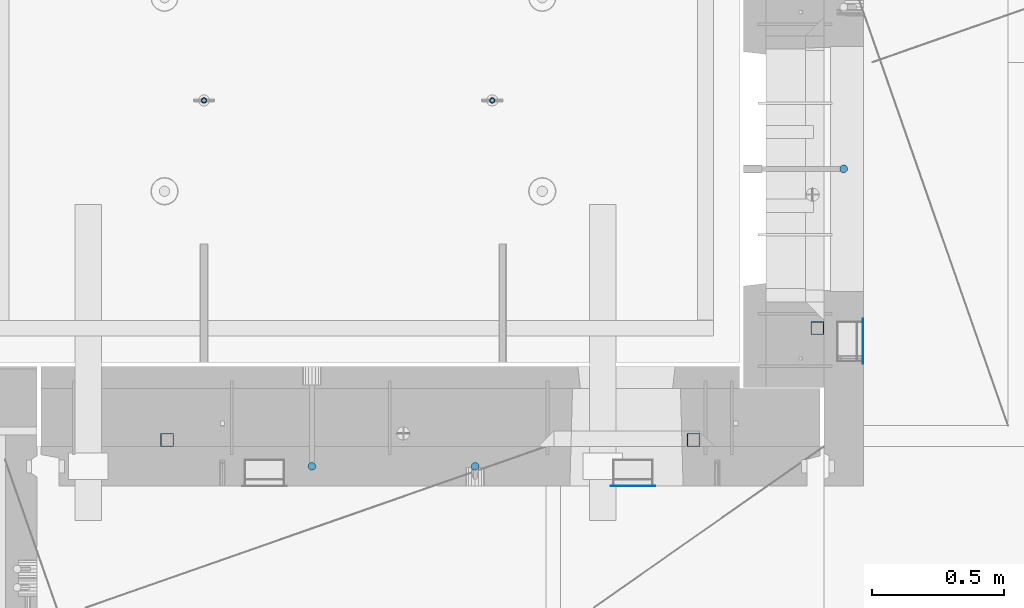
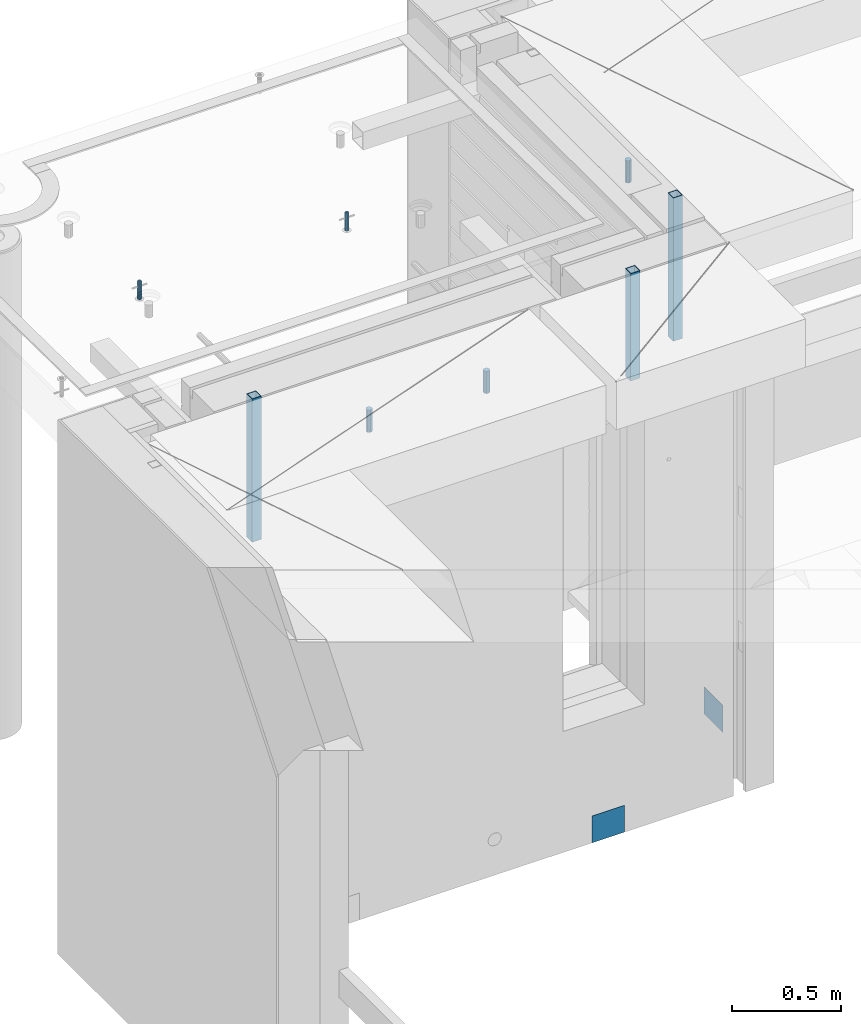
# One storey, part 27 of 349: 10 columns, 10 elements without a shape of their own.
"""IFC2X3 building model written with IfcOpenShell, lengths in millimetres."""

from ifc_helpers import new_model, si_unit, frame, origin_with_axes, place, context, subcontext, project, spatial, faceted_brep, material, type_object, element, aggregate, save


model = new_model("IFC2X3")

# Units and contexts
model_context = context("Model", 3, precision=1e-05, world=origin_with_axes())
body_context = subcontext(model_context, "Body", "Model", "MODEL_VIEW")
ifc_project = project(units=[si_unit("LENGTHUNIT", "METRE", prefix="MILLI"), si_unit("AREAUNIT", "SQUARE_METRE"), si_unit("VOLUMEUNIT", "CUBIC_METRE"), si_unit("MASSUNIT", "GRAM", prefix="KILO"), si_unit("TIMEUNIT", "SECOND"), si_unit("PLANEANGLEUNIT", "RADIAN"), si_unit("SOLIDANGLEUNIT", "STERADIAN"), si_unit("THERMODYNAMICTEMPERATUREUNIT", "DEGREE_CELSIUS"), si_unit("LUMINOUSINTENSITYUNIT", "LUMEN")], contexts=[model_context])

# Site, building, storey
site_placement = place(None, origin_with_axes())
site = spatial("IfcSite", under=ifc_project, at=site_placement, CompositionType="ELEMENT")
building_placement = place(site_placement, origin_with_axes())
building = spatial("IfcBuilding", under=site, at=building_placement, CompositionType="ELEMENT")
storey_placement = place(building_placement, origin_with_axes())
storey = spatial("IfcBuildingStorey", under=building, at=storey_placement, Name="4", CompositionType="ELEMENT", Elevation=0.0)

# Assembly, column
assembly_1_placement = place(storey_placement, origin_with_axes())
assembly_1 = element("IfcElementAssembly", 1, at=assembly_1_placement, inside=storey, AssemblyPlace="NOTDEFINED", PredefinedType="REINFORCEMENT_UNIT")
ifc_material_1 = material()
column_type_1 = type_object("IfcColumnType", Name="D30", PredefinedType="NOTDEFINED")
column_1_placement = place(assembly_1_placement, frame((11064.9999999907, 21634.9982799657, 93407.5), z_axis=(1.0, 0.0, 0.0), x_axis=(0.0, 0.0, 1.0)))
column_1 = element("IfcColumn", 2, at=column_1_placement, type_object=column_type_1, material=ifc_material_1, ObjectType="D30", context=body_context, shape_type="Brep", body=[
    faceted_brep([(0.0, -15.0, 0.0), (0.0, -12.9903810567666, -7.5), (125.0, -12.9903810567666, -7.5), (125.0, -15.0, 0.0), (0.0, -7.5, -12.9903810567666), (125.0, -7.5, -12.9903810567666), (0.0, 0.0, -15.0), (125.0, 0.0, -15.0), (0.0, 7.5, -12.9903810567666), (125.0, 7.5, -12.9903810567666), (0.0, 12.9903810567666, -7.5), (125.0, 12.9903810567666, -7.5), (0.0, 15.0, 0.0), (125.0, 15.0, 0.0), (0.0, 12.9903810567666, 7.5), (125.0, 12.9903810567666, 7.5), (0.0, 7.5, 12.9903810567666), (125.0, 7.5, 12.9903810567666), (0.0, 0.0, 15.0), (125.0, 0.0, 15.0), (0.0, -7.5, 12.9903810567666), (125.0, -7.5, 12.9903810567666), (0.0, -12.9903810567666, 7.5), (125.0, -12.9903810567666, 7.5)], [[[0, 1, 2, 3]], [[1, 4, 5, 2]], [[4, 6, 7, 5]], [[6, 8, 9, 7]], [[8, 10, 11, 9]], [[10, 12, 13, 11]], [[12, 14, 15, 13]], [[14, 16, 17, 15]], [[16, 18, 19, 17]], [[18, 20, 21, 19]], [[20, 22, 23, 21]], [[22, 0, 3, 23]], [[5, 7, 9, 11, 13, 15, 17, 19, 21, 23, 3, 2]], [[22, 20, 18, 16, 14, 12, 10, 8, 6, 4, 1, 0]]]),
])

# Assembly, columns
assembly_2_placement = place(storey_placement, origin_with_axes())
assembly_2 = element("IfcElementAssembly", 3, at=assembly_2_placement, inside=storey, AssemblyPlace="NOTDEFINED", PredefinedType="REINFORCEMENT_UNIT")
column_2_placement = place(assembly_2_placement, frame((9665.00172003435, 20504.9951872276, 93407.5), z_axis=(0.0, 1.0, 0.0), x_axis=(0.0, 0.0, 1.0)))
column_2 = element("IfcColumn", 4, at=column_2_placement, type_object=column_type_1, material=ifc_material_1, ObjectType="D30", context=body_context, shape_type="Brep", body=[
    faceted_brep([(0.0, -15.0, 0.0), (0.0, -12.9903810567666, -7.5), (125.0, -12.9903810567666, -7.5), (125.0, -15.0, 0.0), (0.0, -7.5, -12.9903810567666), (125.0, -7.5, -12.9903810567666), (0.0, 0.0, -15.0), (125.0, 0.0, -15.0), (0.0, 7.5, -12.9903810567666), (125.0, 7.5, -12.9903810567666), (0.0, 12.9903810567666, -7.5), (125.0, 12.9903810567666, -7.5), (0.0, 15.0, 0.0), (125.0, 15.0, 0.0), (0.0, 12.9903810567666, 7.5), (125.0, 12.9903810567666, 7.5), (0.0, 7.5, 12.9903810567666), (125.0, 7.5, 12.9903810567666), (0.0, 0.0, 15.0), (125.0, 0.0, 15.0), (0.0, -7.5, 12.9903810567666), (125.0, -7.5, 12.9903810567666), (0.0, -12.9903810567666, 7.5), (125.0, -12.9903810567666, 7.5)], [[[0, 1, 2, 3]], [[1, 4, 5, 2]], [[4, 6, 7, 5]], [[6, 8, 9, 7]], [[8, 10, 11, 9]], [[10, 12, 13, 11]], [[12, 14, 15, 13]], [[14, 16, 17, 15]], [[16, 18, 19, 17]], [[18, 20, 21, 19]], [[20, 22, 23, 21]], [[22, 0, 3, 23]], [[5, 7, 9, 11, 13, 15, 17, 19, 21, 23, 3, 2]], [[22, 20, 18, 16, 14, 12, 10, 8, 6, 4, 1, 0]]]),
])
column_3_placement = place(assembly_2_placement, frame((9045.00366673532, 20504.9951872205, 93407.5), z_axis=(0.0, -1.0, 0.0), x_axis=(0.0, 0.0, 1.0)))
column_3 = element("IfcColumn", 5, at=column_3_placement, type_object=column_type_1, material=ifc_material_1, ObjectType="D30", context=body_context, shape_type="Brep", body=[
    faceted_brep([(0.0, -15.0, 0.0), (0.0, -12.9903810567666, -7.5), (125.0, -12.9903810567666, -7.5), (125.0, -15.0, 0.0), (0.0, -7.5, -12.9903810567666), (125.0, -7.5, -12.9903810567666), (0.0, 0.0, -15.0), (125.0, 0.0, -15.0), (0.0, 7.5, -12.9903810567666), (125.0, 7.5, -12.9903810567666), (0.0, 12.9903810567666, -7.5), (125.0, 12.9903810567666, -7.5), (0.0, 15.0, 0.0), (125.0, 15.0, 0.0), (0.0, 12.9903810567666, 7.5), (125.0, 12.9903810567666, 7.5), (0.0, 7.5, 12.9903810567666), (125.0, 7.5, 12.9903810567666), (0.0, 0.0, 15.0), (125.0, 0.0, 15.0), (0.0, -7.5, 12.9903810567666), (125.0, -7.5, 12.9903810567666), (0.0, -12.9903810567666, 7.5), (125.0, -12.9903810567666, 7.5)], [[[0, 1, 2, 3]], [[1, 4, 5, 2]], [[4, 6, 7, 5]], [[6, 8, 9, 7]], [[8, 10, 11, 9]], [[10, 12, 13, 11]], [[12, 14, 15, 13]], [[14, 16, 17, 15]], [[16, 18, 19, 17]], [[18, 20, 21, 19]], [[20, 22, 23, 21]], [[22, 0, 3, 23]], [[5, 7, 9, 11, 13, 15, 17, 19, 21, 23, 3, 2]], [[22, 20, 18, 16, 14, 12, 10, 8, 6, 4, 1, 0]]]),
])

# Assembly, column
assembly_3_placement = place(assembly_1_placement, origin_with_axes())
assembly_3 = element("IfcElementAssembly", 6, at=assembly_3_placement, Name="Steel Assembly", AssemblyPlace="NOTDEFINED", PredefinedType="NOTDEFINED")
ifc_material_2 = material(Name="Undefined")
column_type_2 = type_object("IfcColumnType", PredefinedType="NOTDEFINED")
column_4_placement = place(assembly_3_placement, frame((11139.0000000031, 20979.9951872276, 90754.9999999969), z_axis=(1.0, 0.0, 0.0), x_axis=(0.0, 0.0, 1.0)))
column_4 = element("IfcColumn", 7, at=column_4_placement, type_object=column_type_2, material=ifc_material_2, Name="SPK2", context=body_context, shape_type="Brep", body=[
    faceted_brep([(0.0, 85.0, -1.0), (0.0, 85.0, 1.0), (150.0, 85.0, 1.0), (150.0, 85.0, -1.0), (0.0, -85.0, 1.0), (150.0, -85.0, 1.0), (0.0, -85.0, -1.0), (150.0, -85.0, -1.0)], [[[0, 1, 2, 3]], [[1, 4, 5, 2]], [[4, 6, 7, 5]], [[6, 0, 3, 7]], [[5, 7, 3, 2]], [[6, 4, 1, 0]]]),
])
aggregate(assembly_3, [column_4])

assembly_4_placement = place(assembly_2_placement, origin_with_axes())
assembly_4 = element("IfcElementAssembly", 8, at=assembly_4_placement, Name="Steel Assembly", AssemblyPlace="NOTDEFINED", PredefinedType="NOTDEFINED")
column_5_placement = place(assembly_4_placement, frame((10265.0, 20430.9951872214, 90755.0), z_axis=(0.0, -1.0, 0.0), x_axis=(0.0, 0.0, 1.0)))
column_5 = element("IfcColumn", 9, at=column_5_placement, type_object=column_type_2, material=ifc_material_2, Name="SPK2", context=body_context, shape_type="Brep", body=[
    faceted_brep([(0.0, 85.0, -1.0), (0.0, 85.0, 1.0), (150.0, 85.0, 1.0), (150.0, 85.0, -1.0), (0.0, -85.0, 1.0), (150.0, -85.0, 1.0), (0.0, -85.0, -1.0), (150.0, -85.0, -1.0)], [[[0, 1, 2, 3]], [[1, 4, 5, 2]], [[4, 6, 7, 5]], [[6, 0, 3, 7]], [[5, 7, 3, 2]], [[6, 4, 1, 0]]]),
])
aggregate(assembly_4, [column_5])

# Assembly
assembly_5_placement = place(assembly_1_placement, origin_with_axes())
assembly_5 = element("IfcElementAssembly", 10, at=assembly_5_placement, Name="Steel Assembly", AssemblyPlace="NOTDEFINED", PredefinedType="RIGID_FRAME")

aggregate(assembly_1, [column_1, assembly_3, assembly_5])

# Column
ifc_material_3 = material(Name="STEEL/S355J2")
column_type_3 = type_object("IfcColumnType", Name="50X50X3", PredefinedType="NOTDEFINED")
column_6_placement = place(assembly_5_placement, frame((10965.0, 21030.0, 92940.0), z_axis=(1.0, 0.0, 0.0), x_axis=(0.0, 0.0, 1.0)))
column_6 = element("IfcColumn", 11, at=column_6_placement, type_object=column_type_3, material=ifc_material_3, ObjectType="50X50X3", context=body_context, shape_type="Brep", body=[
    faceted_brep([(0.0, 22.0, -22.0), (0.0, -22.0, -22.0), (800.0, -22.0, -22.0), (800.0, 22.0, -22.0), (0.0, -22.0, 22.0), (800.0, -22.0, 22.0), (0.0, 22.0, 22.0), (800.0, 22.0, 22.0), (0.0, 25.0, -25.0), (0.0, 25.0, 25.0), (800.0, 25.0, 25.0), (800.0, 25.0, -25.0), (0.0, -25.0, 25.0), (800.0, -25.0, 25.0), (0.0, -25.0, -25.0), (800.0, -25.0, -25.0)], [[[0, 1, 2, 3]], [[1, 4, 5, 2]], [[4, 6, 7, 5]], [[6, 0, 3, 7]], [[8, 9, 10, 11]], [[9, 12, 13, 10]], [[12, 14, 15, 13]], [[14, 8, 11, 15]], [[13, 15, 11, 10], [5, 7, 3, 2]], [[14, 12, 9, 8], [6, 4, 1, 0]]]),
])

aggregate(assembly_5, [column_6])

# Assembly, column
assembly_6_placement = place(assembly_2_placement, origin_with_axes())
assembly_6 = element("IfcElementAssembly", 12, at=assembly_6_placement, Name="Steel Assembly", AssemblyPlace="NOTDEFINED", PredefinedType="RIGID_FRAME")
column_7_placement = place(assembly_6_placement, frame((8495.0, 20605.0, 92940.0), z_axis=(1.0, 0.0, 0.0), x_axis=(0.0, 0.0, 1.0)))
column_7 = element("IfcColumn", 13, at=column_7_placement, type_object=column_type_3, material=ifc_material_3, ObjectType="50X50X3", context=body_context, shape_type="Brep", body=[
    faceted_brep([(0.0, 22.0, -22.0), (0.0, -22.0, -22.0), (800.0, -22.0, -22.0), (800.0, 22.0, -22.0), (0.0, -22.0, 22.0), (800.0, -22.0, 22.0), (0.0, 22.0, 22.0), (800.0, 22.0, 22.0), (0.0, 25.0, -25.0), (0.0, 25.0, 25.0), (800.0, 25.0, 25.0), (800.0, 25.0, -25.0), (0.0, -25.0, 25.0), (800.0, -25.0, 25.0), (0.0, -25.0, -25.0), (800.0, -25.0, -25.0)], [[[0, 1, 2, 3]], [[1, 4, 5, 2]], [[4, 6, 7, 5]], [[6, 0, 3, 7]], [[8, 9, 10, 11]], [[9, 12, 13, 10]], [[12, 14, 15, 13]], [[14, 8, 11, 15]], [[13, 15, 11, 10], [5, 7, 3, 2]], [[14, 12, 9, 8], [6, 4, 1, 0]]]),
])
aggregate(assembly_6, [column_7])

# Assembly
assembly_7_placement = place(assembly_2_placement, origin_with_axes())
assembly_7 = element("IfcElementAssembly", 14, at=assembly_7_placement, Name="Steel Assembly", AssemblyPlace="NOTDEFINED", PredefinedType="RIGID_FRAME")

aggregate(assembly_2, [column_2, column_3, assembly_4, assembly_6, assembly_7])

# Column
column_8_placement = place(assembly_7_placement, frame((10495.0, 20605.0, 93140.0), z_axis=(1.0, 0.0, 0.0), x_axis=(0.0, 0.0, 1.0)))
column_8 = element("IfcColumn", 15, at=column_8_placement, type_object=column_type_3, material=ifc_material_3, ObjectType="50X50X3", context=body_context, shape_type="Brep", body=[
    faceted_brep([(0.0, 22.0, -22.0), (0.0, -22.0, -22.0), (600.0, -22.0, -22.0), (600.0, 22.0, -22.0), (0.0, -22.0, 22.0), (600.0, -22.0, 22.0), (0.0, 22.0, 22.0), (600.0, 22.0, 22.0), (0.0, 25.0, -25.0), (0.0, 25.0, 25.0), (600.0, 25.0, 25.0), (600.0, 25.0, -25.0), (0.0, -25.0, 25.0), (600.0, -25.0, 25.0), (0.0, -25.0, -25.0), (600.0, -25.0, -25.0)], [[[0, 1, 2, 3]], [[1, 4, 5, 2]], [[4, 6, 7, 5]], [[6, 0, 3, 7]], [[8, 9, 10, 11]], [[9, 12, 13, 10]], [[12, 14, 15, 13]], [[14, 8, 11, 15]], [[13, 15, 11, 10], [5, 7, 3, 2]], [[14, 12, 9, 8], [6, 4, 1, 0]]]),
])

aggregate(assembly_7, [column_8])

# Assemblies, columns
assembly_8_placement = place(storey_placement, origin_with_axes())
assembly_8 = element("IfcElementAssembly", 16, at=assembly_8_placement, inside=storey, AssemblyPlace="NOTDEFINED", PredefinedType="REINFORCEMENT_UNIT")
assembly_9_placement = place(assembly_8_placement, origin_with_axes())
assembly_9 = element("IfcElementAssembly", 17, at=assembly_9_placement, Name="Steel Assembly", AssemblyPlace="NOTDEFINED", PredefinedType="RIGID_FRAME")
ifc_material_4 = material(Name="STEEL/1.4301")
column_type_4 = type_object("IfcColumnType", PredefinedType="NOTDEFINED")
column_9_placement = place(assembly_9_placement, frame((8634.9865866494, 21895.0212615308, 93444.9999983246), z_axis=(-1.60829999983552e-05, -0.999999999870669, 0.0), x_axis=(0.0, 0.0, 1.0)))
column_9 = element("IfcColumn", 18, at=column_9_placement, type_object=column_type_4, material=ifc_material_4, context=body_context, shape_type="Brep", body=[
    faceted_brep([(0.0, -8.0, 0.0), (0.0, -6.92820323027263, 4.0), (100.000000000029, -6.92820323027263, 4.0), (100.000000000029, -7.99999999999636, 0.0), (0.0, -4.0, 6.92820323027627), (100.000000000029, -4.0, 6.92820323027536), (0.0, 0.0, 8.0), (100.000000000029, 3.63797880709171e-12, 8.0), (0.0, 4.0, 6.92820323027627), (100.000000000029, 4.0, 6.92820323027536), (0.0, 6.92820323027263, 4.0), (100.000000000029, 6.92820323027627, 3.99999999999909), (0.0, 8.0, 0.0), (100.000000000029, 8.0, 0.0), (0.0, 6.92820323027263, -4.0), (100.000000000029, 6.92820323027627, -4.00000000000091), (0.0, 4.0, -6.92820323027627), (100.000000000029, 4.00000000000364, -6.92820323027536), (0.0, 0.0, -8.0), (100.000000000029, 3.63797880709171e-12, -8.00000000000091), (0.0, -4.0, -6.92820323027627), (100.000000000029, -3.99999999999636, -6.92820323027627), (0.0, -6.92820323027263, -4.0), (100.000000000029, -6.92820323027263, -4.0), (0.0, -10.4999999999927, -1.45519152283669e-11), (0.0, -9.09326673972828, -5.25000000001455), (100.000000000262, -9.09326673972828, -5.25000000001455), (100.000000000262, -10.4999999999927, -1.45519152283669e-11), (0.0, -5.24999999998545, -9.09326673974283), (100.000000000262, -5.24999999998545, -9.09326673974283), (0.0, 7.27595761418343e-12, -10.5), (100.000000000262, 7.27595761418343e-12, -10.5), (0.0, 5.25000000001455, -9.09326673975738), (100.000000000262, 5.25000000001455, -9.09326673975738), (0.0, 9.09326673975011, -5.25000000001455), (100.000000000262, 9.09326673975011, -5.25000000001455), (0.0, 10.5000000000073, -1.45519152283669e-11), (100.000000000262, 10.5000000000073, -1.45519152283669e-11), (0.0, 9.09326673975011, 5.25), (100.000000000262, 9.09326673975011, 5.25), (0.0, 5.25000000000728, 9.09326673972828), (100.000000000262, 5.25000000000728, 9.09326673972828), (0.0, 1.45519152283669e-11, 10.4999999999854), (100.000000000262, 1.45519152283669e-11, 10.4999999999854), (0.0, -5.24999999999272, 9.09326673972828), (100.000000000262, -5.24999999999272, 9.09326673972828), (0.0, -9.09326673972828, 5.24999999998545), (100.000000000262, -9.09326673972828, 5.24999999998545)], [[[0, 1, 2, 3]], [[1, 4, 5, 2]], [[4, 6, 7, 5]], [[6, 8, 9, 7]], [[8, 10, 11, 9]], [[10, 12, 13, 11]], [[12, 14, 15, 13]], [[14, 16, 17, 15]], [[16, 18, 19, 17]], [[18, 20, 21, 19]], [[20, 22, 23, 21]], [[22, 0, 3, 23]], [[24, 25, 26, 27]], [[25, 28, 29, 26]], [[28, 30, 31, 29]], [[30, 32, 33, 31]], [[32, 34, 35, 33]], [[34, 36, 37, 35]], [[36, 38, 39, 37]], [[38, 40, 41, 39]], [[40, 42, 43, 41]], [[42, 44, 45, 43]], [[44, 46, 47, 45]], [[46, 24, 27, 47]], [[29, 31, 33, 35, 37, 39, 41, 43, 45, 47, 27, 26], [5, 7, 9, 11, 13, 15, 17, 19, 21, 23, 3, 2]], [[46, 44, 42, 40, 38, 36, 34, 32, 30, 28, 25, 24], [22, 20, 18, 16, 14, 12, 10, 8, 6, 4, 1, 0]]]),
])
aggregate(assembly_9, [column_9])
assembly_10_placement = place(assembly_8_placement, origin_with_axes())
assembly_10 = element("IfcElementAssembly", 19, at=assembly_10_placement, Name="Steel Assembly", AssemblyPlace="NOTDEFINED", PredefinedType="RIGID_FRAME")
aggregate(assembly_8, [assembly_9, assembly_10])
column_10_placement = place(assembly_10_placement, frame((9729.98658651215, 21895.0041915483, 93444.9999983246), z_axis=(-1.60829999983552e-05, -0.999999999870669, 0.0), x_axis=(0.0, 0.0, 1.0)))
column_10 = element("IfcColumn", 20, at=column_10_placement, type_object=column_type_4, material=ifc_material_4, context=body_context, shape_type="Brep", body=[
    faceted_brep([(0.0, -8.0, 0.0), (0.0, -6.92820323027263, 4.0), (100.000000000029, -6.92820323027263, 4.0), (100.000000000029, -7.99999999999636, 0.0), (0.0, -4.0, 6.92820323027627), (100.000000000029, -4.0, 6.92820323027536), (0.0, 0.0, 8.0), (100.000000000029, 3.63797880709171e-12, 8.0), (0.0, 4.0, 6.92820323027627), (100.000000000029, 4.0, 6.92820323027536), (0.0, 6.92820323027263, 4.0), (100.000000000029, 6.92820323027627, 3.99999999999909), (0.0, 8.0, 0.0), (100.000000000029, 8.0, 0.0), (0.0, 6.92820323027263, -4.0), (100.000000000029, 6.92820323027627, -4.00000000000091), (0.0, 4.0, -6.92820323027627), (100.000000000029, 4.00000000000364, -6.92820323027536), (0.0, 0.0, -8.0), (100.000000000029, 3.63797880709171e-12, -8.00000000000091), (0.0, -4.0, -6.92820323027627), (100.000000000029, -3.99999999999636, -6.92820323027627), (0.0, -6.92820323027263, -4.0), (100.000000000029, -6.92820323027263, -4.0), (0.0, -10.4999999999927, -1.45519152283669e-11), (0.0, -9.09326673972828, -5.25000000001455), (100.000000000262, -9.09326673972828, -5.25000000001455), (100.000000000262, -10.4999999999927, -1.45519152283669e-11), (0.0, -5.24999999998545, -9.09326673974283), (100.000000000262, -5.24999999998545, -9.09326673974283), (0.0, 7.27595761418343e-12, -10.5), (100.000000000262, 7.27595761418343e-12, -10.5), (0.0, 5.25000000001455, -9.09326673975738), (100.000000000262, 5.25000000001455, -9.09326673975738), (0.0, 9.09326673975011, -5.25000000001455), (100.000000000262, 9.09326673975011, -5.25000000001455), (0.0, 10.5000000000073, -1.45519152283669e-11), (100.000000000262, 10.5000000000073, -1.45519152283669e-11), (0.0, 9.09326673975011, 5.25), (100.000000000262, 9.09326673975011, 5.25), (0.0, 5.25000000000728, 9.09326673972828), (100.000000000262, 5.25000000000728, 9.09326673972828), (0.0, 1.45519152283669e-11, 10.4999999999854), (100.000000000262, 1.45519152283669e-11, 10.4999999999854), (0.0, -5.24999999999272, 9.09326673972828), (100.000000000262, -5.24999999999272, 9.09326673972828), (0.0, -9.09326673972828, 5.24999999998545), (100.000000000262, -9.09326673972828, 5.24999999998545)], [[[0, 1, 2, 3]], [[1, 4, 5, 2]], [[4, 6, 7, 5]], [[6, 8, 9, 7]], [[8, 10, 11, 9]], [[10, 12, 13, 11]], [[12, 14, 15, 13]], [[14, 16, 17, 15]], [[16, 18, 19, 17]], [[18, 20, 21, 19]], [[20, 22, 23, 21]], [[22, 0, 3, 23]], [[24, 25, 26, 27]], [[25, 28, 29, 26]], [[28, 30, 31, 29]], [[30, 32, 33, 31]], [[32, 34, 35, 33]], [[34, 36, 37, 35]], [[36, 38, 39, 37]], [[38, 40, 41, 39]], [[40, 42, 43, 41]], [[42, 44, 45, 43]], [[44, 46, 47, 45]], [[46, 24, 27, 47]], [[29, 31, 33, 35, 37, 39, 41, 43, 45, 47, 27, 26], [5, 7, 9, 11, 13, 15, 17, 19, 21, 23, 3, 2]], [[46, 44, 42, 40, 38, 36, 34, 32, 30, 28, 25, 24], [22, 20, 18, 16, 14, 12, 10, 8, 6, 4, 1, 0]]]),
])
aggregate(assembly_10, [column_10])

save(model, "model.ifc")
